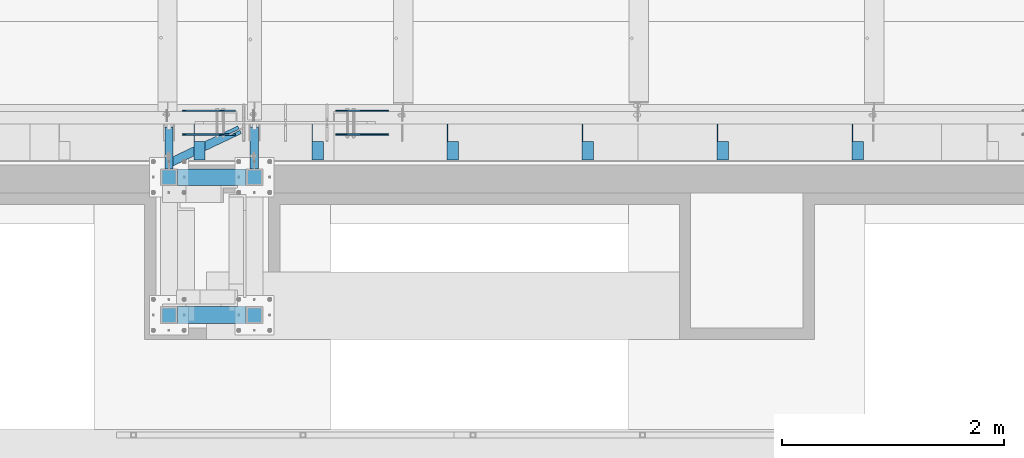
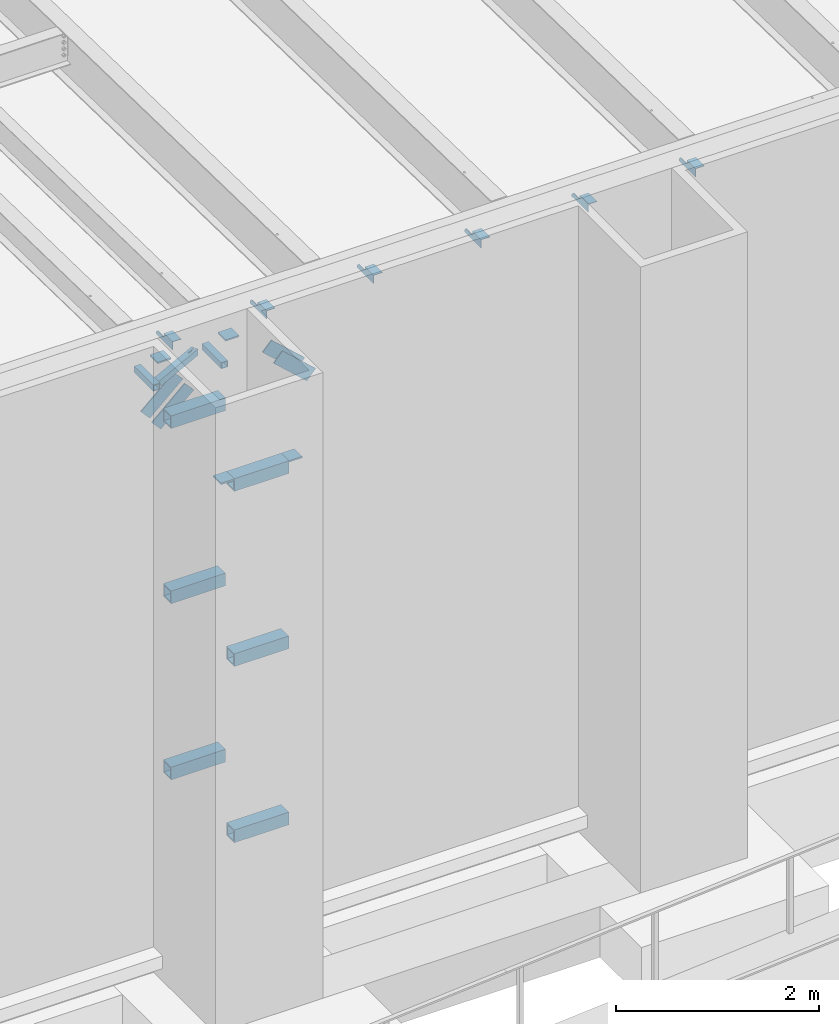
# One storey, part 1178 of 1763: 19 beams, 4 members, 7 elements without a shape of their own.
"""IFC2X3 building model written with IfcOpenShell, lengths in millimetres."""

from ifc_helpers import new_model, si_unit, frame, origin_with_axes, place, context, subcontext, project, spatial, faceted_brep, material, type_object, element, aggregate, save


model = new_model("IFC2X3")

# Units and contexts
model_context = context("Model", 3, precision=1e-05, world=origin_with_axes())
body_context = subcontext(model_context, "Body", "Model", "MODEL_VIEW")
ifc_project = project(units=[si_unit("LENGTHUNIT", "METRE", prefix="MILLI"), si_unit("AREAUNIT", "SQUARE_METRE"), si_unit("VOLUMEUNIT", "CUBIC_METRE"), si_unit("MASSUNIT", "GRAM", prefix="KILO"), si_unit("TIMEUNIT", "SECOND"), si_unit("PLANEANGLEUNIT", "RADIAN"), si_unit("SOLIDANGLEUNIT", "STERADIAN"), si_unit("THERMODYNAMICTEMPERATUREUNIT", "DEGREE_CELSIUS"), si_unit("LUMINOUSINTENSITYUNIT", "LUMEN")], contexts=[model_context])

# Site, building, storey
site_placement = place(None, origin_with_axes())
site = spatial("IfcSite", under=ifc_project, at=site_placement, CompositionType="ELEMENT")
building_placement = place(site_placement, origin_with_axes())
building = spatial("IfcBuilding", under=site, at=building_placement, Name="Undefined", CompositionType="ELEMENT")
storey_placement = place(building_placement, origin_with_axes())
storey = spatial("IfcBuildingStorey", under=building, at=storey_placement, Name="Undefined", CompositionType="ELEMENT", Elevation=0.0)

# Assembly, beams
assembly_1_placement = place(storey_placement, origin_with_axes())
assembly_1 = element("IfcElementAssembly", 1, at=assembly_1_placement, inside=storey, Name="BEAM", AssemblyPlace="NOTDEFINED", PredefinedType="RIGID_FRAME")
ifc_material_1 = material(Name="STEEL/A36")
beam_type_1 = type_object("IfcBeamType", Name="L4X4X1/4", PredefinedType="NOTDEFINED")
beam_1_placement = place(assembly_1_placement, frame((-74765.2055562792, -13727.9060747204, 12153.8999999998), z_axis=(0.0, 0.0, -1.0), x_axis=(0.0, -1.0, 0.0)))
beam_1 = element("IfcBeam", 2, at=beam_1_placement, type_object=beam_type_1, material=ifc_material_1, Name="BRACE", ObjectType="L4X4X1/4", context=body_context, shape_type="Brep", body=[
    faceted_brep([(156.368743896541, 44.4499999999971, -6.34999904595679), (156.368743896541, 50.8000000000029, -6.34999904595679), (156.368743896533, 50.8000000000029, -50.7999999999993), (156.368743896533, -50.8000000000029, -50.7999999999993), (156.368743896535, -50.8000000000029, -44.4500000000007), (156.368743896535, 44.4499999999971, -44.4500000000007), (31.7499984742426, 44.4500000000007, -6.35000000027321), (31.7499984742426, 50.7999999999993, -6.35000038323415), (-1.81898940354586e-10, 44.4500000000371, 50.7999999999374), (-1.96450855582952e-10, 50.8000000000393, 50.7999999999374), (0.0, 50.7999999999993, 25.3999999997268), (0.0, 44.4500000000007, 25.3999999997268), (324.643737794, 44.4500000000007, 50.7999999999993), (324.643737794, 50.7999999999993, 50.7999999999993), (324.643737794, 44.4500000000007, -44.4500000000007), (324.643737794, -50.7999999999993, -44.4500000000007), (324.643737794, -50.7999999999993, -50.7999999999993), (324.643737794, 50.7999999999993, -50.7999999999993)], [[[0, 1, 2, 3, 4, 5]], [[6, 7, 1, 0]], [[8, 9, 10, 11]], [[9, 8, 12, 13]], [[12, 14, 15, 16, 17, 13]], [[15, 14, 5, 4]], [[16, 15, 4, 3]], [[17, 16, 3, 2]], [[10, 9, 13, 17, 2, 1, 7]], [[6, 11, 10, 7]], [[14, 12, 8, 11, 6, 0, 5]]]),
])
beam_2_placement = place(assembly_1_placement, frame((-75984.4055562792, -13727.9060747204, 12153.8999999998), z_axis=(0.0, 0.0, -1.0), x_axis=(0.0, -1.0, 0.0)))
beam_2 = element("IfcBeam", 3, at=beam_2_placement, type_object=beam_type_1, material=ifc_material_1, Name="BRACE", ObjectType="L4X4X1/4", context=body_context, shape_type="Brep", body=[
    faceted_brep([(156.368743896541, 44.4499999999971, -6.34999904595679), (156.368743896541, 50.8000000000029, -6.34999904595679), (156.368743896533, 50.8000000000029, -50.7999999999993), (156.368743896533, -50.8000000000029, -50.7999999999993), (156.368743896535, -50.8000000000029, -44.4500000000007), (156.368743896535, 44.4499999999971, -44.4500000000007), (31.7499984742426, 44.4500000000007, -6.35000000027321), (31.7499984742426, 50.7999999999993, -6.35000038323415), (-1.81898940354586e-10, 44.4500000000371, 50.7999999999374), (-1.96450855582952e-10, 50.8000000000393, 50.7999999999374), (0.0, 50.7999999999993, 25.3999999997268), (0.0, 44.4500000000007, 25.3999999997268), (324.643737794, 44.4500000000007, 50.7999999999993), (324.643737794, 50.7999999999993, 50.7999999999993), (324.643737794, 44.4500000000007, -44.4500000000007), (324.643737794, -50.7999999999993, -44.4500000000007), (324.643737794, -50.7999999999993, -50.7999999999993), (324.643737794, 50.7999999999993, -50.7999999999993)], [[[0, 1, 2, 3, 4, 5]], [[6, 7, 1, 0]], [[8, 9, 10, 11]], [[9, 8, 12, 13]], [[12, 14, 15, 16, 17, 13]], [[15, 14, 5, 4]], [[16, 15, 4, 3]], [[17, 16, 3, 2]], [[10, 9, 13, 17, 2, 1, 7]], [[6, 11, 10, 7]], [[14, 12, 8, 11, 6, 0, 5]]]),
])
beam_3_placement = place(assembly_1_placement, frame((-77203.6055562792, -13727.9060747203, 12153.8999999998), z_axis=(0.0, 0.0, -1.0), x_axis=(0.0, -1.0, 0.0)))
beam_3 = element("IfcBeam", 4, at=beam_3_placement, type_object=beam_type_1, material=ifc_material_1, Name="BRACE", ObjectType="L4X4X1/4", context=body_context, shape_type="Brep", body=[
    faceted_brep([(156.368743896541, 44.4499999999971, -6.34999904595679), (156.368743896541, 50.8000000000029, -6.34999904595679), (156.368743896533, 50.8000000000029, -50.7999999999993), (156.368743896533, -50.8000000000029, -50.7999999999993), (156.368743896535, -50.8000000000029, -44.4500000000007), (156.368743896535, 44.4499999999971, -44.4500000000007), (31.7499984742426, 44.4500000000007, -6.35000000027321), (31.7499984742426, 50.7999999999993, -6.35000038323415), (-1.81898940354586e-10, 44.4500000000371, 50.7999999999374), (-1.96450855582952e-10, 50.8000000000393, 50.7999999999374), (0.0, 50.7999999999993, 25.3999999997268), (0.0, 44.4500000000007, 25.3999999997268), (324.643737794, 44.4500000000007, 50.7999999999993), (324.643737794, 50.7999999999993, 50.7999999999993), (324.643737794, 44.4500000000007, -44.4500000000007), (324.643737794, -50.7999999999993, -44.4500000000007), (324.643737794, -50.7999999999993, -50.7999999999993), (324.643737794, 50.7999999999993, -50.7999999999993)], [[[0, 1, 2, 3, 4, 5]], [[6, 7, 1, 0]], [[8, 9, 10, 11]], [[9, 8, 12, 13]], [[12, 14, 15, 16, 17, 13]], [[15, 14, 5, 4]], [[16, 15, 4, 3]], [[17, 16, 3, 2]], [[10, 9, 13, 17, 2, 1, 7]], [[6, 11, 10, 7]], [[14, 12, 8, 11, 6, 0, 5]]]),
])
beam_4_placement = place(assembly_1_placement, frame((-78422.8055562793, -13727.9060747202, 12153.8999999998), z_axis=(0.0, 0.0, -1.0), x_axis=(0.0, -1.0, 0.0)))
beam_4 = element("IfcBeam", 5, at=beam_4_placement, type_object=beam_type_1, material=ifc_material_1, Name="BRACE", ObjectType="L4X4X1/4", context=body_context, shape_type="Brep", body=[
    faceted_brep([(156.368743896541, 44.4499999999971, -6.34999904595679), (156.368743896541, 50.8000000000029, -6.34999904595679), (156.368743896533, 50.8000000000029, -50.7999999999993), (156.368743896533, -50.8000000000029, -50.7999999999993), (156.368743896535, -50.8000000000029, -44.4500000000007), (156.368743896535, 44.4499999999971, -44.4500000000007), (31.7499984742426, 44.4500000000007, -6.35000000027321), (31.7499984742426, 50.7999999999993, -6.35000038323415), (-1.81898940354586e-10, 44.4500000000371, 50.7999999999374), (-1.96450855582952e-10, 50.8000000000393, 50.7999999999374), (0.0, 50.7999999999993, 25.3999999997268), (0.0, 44.4500000000007, 25.3999999997268), (324.643737794, 44.4500000000007, 50.7999999999993), (324.643737794, 50.7999999999993, 50.7999999999993), (324.643737794, 44.4500000000007, -44.4500000000007), (324.643737794, -50.7999999999993, -44.4500000000007), (324.643737794, -50.7999999999993, -50.7999999999993), (324.643737794, 50.7999999999993, -50.7999999999993)], [[[0, 1, 2, 3, 4, 5]], [[6, 7, 1, 0]], [[8, 9, 10, 11]], [[9, 8, 12, 13]], [[12, 14, 15, 16, 17, 13]], [[15, 14, 5, 4]], [[16, 15, 4, 3]], [[17, 16, 3, 2]], [[10, 9, 13, 17, 2, 1, 7]], [[6, 11, 10, 7]], [[14, 12, 8, 11, 6, 0, 5]]]),
])
beam_5_placement = place(assembly_1_placement, frame((-79642.0055562793, -13727.9060747201, 12153.8999999998), z_axis=(0.0, 0.0, -1.0), x_axis=(0.0, -1.0, 0.0)))
beam_5 = element("IfcBeam", 6, at=beam_5_placement, type_object=beam_type_1, material=ifc_material_1, Name="BRACE", ObjectType="L4X4X1/4", context=body_context, shape_type="Brep", body=[
    faceted_brep([(156.368743896541, 44.4499999999971, -6.34999904595679), (156.368743896541, 50.8000000000029, -6.34999904595679), (156.368743896533, 50.8000000000029, -50.7999999999993), (156.368743896533, -50.8000000000029, -50.7999999999993), (156.368743896535, -50.8000000000029, -44.4500000000007), (156.368743896535, 44.4499999999971, -44.4500000000007), (31.7499984742426, 44.4500000000007, -6.35000000027321), (31.7499984742426, 50.7999999999993, -6.35000038323415), (-1.81898940354586e-10, 44.4500000000371, 50.7999999999374), (-1.96450855582952e-10, 50.8000000000393, 50.7999999999374), (0.0, 50.7999999999993, 25.3999999997268), (0.0, 44.4500000000007, 25.3999999997268), (324.643737794, 44.4500000000007, 50.7999999999993), (324.643737794, 50.7999999999993, 50.7999999999993), (324.643737794, 44.4500000000007, -44.4500000000007), (324.643737794, -50.7999999999993, -44.4500000000007), (324.643737794, -50.7999999999993, -50.7999999999993), (324.643737794, 50.7999999999993, -50.7999999999993)], [[[0, 1, 2, 3, 4, 5]], [[6, 7, 1, 0]], [[8, 9, 10, 11]], [[9, 8, 12, 13]], [[12, 14, 15, 16, 17, 13]], [[15, 14, 5, 4]], [[16, 15, 4, 3]], [[17, 16, 3, 2]], [[10, 9, 13, 17, 2, 1, 7]], [[6, 11, 10, 7]], [[14, 12, 8, 11, 6, 0, 5]]]),
])
beam_6_placement = place(assembly_1_placement, frame((-80708.8055562793, -13727.9060747201, 12153.8999999998), z_axis=(0.0, 0.0, -1.0), x_axis=(0.0, -1.0, 0.0)))
beam_6 = element("IfcBeam", 7, at=beam_6_placement, type_object=beam_type_1, material=ifc_material_1, Name="BRACE", ObjectType="L4X4X1/4", context=body_context, shape_type="Brep", body=[
    faceted_brep([(156.368743896541, 44.4499999999971, -6.34999904595679), (156.368743896541, 50.8000000000029, -6.34999904595679), (156.368743896533, 50.8000000000029, -50.7999999999993), (156.368743896533, -50.8000000000029, -50.7999999999993), (156.368743896535, -50.8000000000029, -44.4500000000007), (156.368743896535, 44.4499999999971, -44.4500000000007), (31.7499984742426, 44.4500000000007, -6.35000000027321), (31.7499984742426, 50.7999999999993, -6.35000038323415), (-1.81898940354586e-10, 44.4500000000371, 50.7999999999374), (-1.96450855582952e-10, 50.8000000000393, 50.7999999999374), (0.0, 50.7999999999993, 25.3999999997268), (0.0, 44.4500000000007, 25.3999999997268), (324.643737794, 44.4500000000007, 50.7999999999993), (324.643737794, 50.7999999999993, 50.7999999999993), (324.643737794, 44.4500000000007, -44.4500000000007), (324.643737794, -50.7999999999993, -44.4500000000007), (324.643737794, -50.7999999999993, -50.7999999999993), (324.643737794, 50.7999999999993, -50.7999999999993)], [[[0, 1, 2, 3, 4, 5]], [[6, 7, 1, 0]], [[8, 9, 10, 11]], [[9, 8, 12, 13]], [[12, 14, 15, 16, 17, 13]], [[15, 14, 5, 4]], [[16, 15, 4, 3]], [[17, 16, 3, 2]], [[10, 9, 13, 17, 2, 1, 7]], [[6, 11, 10, 7]], [[14, 12, 8, 11, 6, 0, 5]]]),
])
aggregate(assembly_1, [beam_1, beam_2, beam_3, beam_4, beam_5, beam_6])

# Assembly, beam
assembly_2_placement = place(storey_placement, origin_with_axes())
assembly_2 = element("IfcElementAssembly", 8, at=assembly_2_placement, inside=storey, Name="BEAM", AssemblyPlace="NOTDEFINED", PredefinedType="RIGID_FRAME")
ifc_material_2 = material()
beam_type_2 = type_object("IfcBeamType", Name="HSS3X3X1/4", PredefinedType="NOTDEFINED")
beam_7_placement = place(assembly_2_placement, frame((-80984.1623728712, -14081.1242675181, 11785.6), z_axis=(0.0, 0.0, 1.0), x_axis=(0.903891808817175, 0.427761145913482, 0.0)))
beam_7 = element("IfcBeam", 9, at=beam_7_placement, type_object=beam_type_2, material=ifc_material_2, Name="BEAM", ObjectType="HSS3X3X1/4", context=body_context, shape_type="Brep", body=[
    faceted_brep([(705.172441220871, 6.3451713315626, 38.1000000000004), (597.221478940919, 6.32881239638664, 38.1000000000004), (597.221478940919, 6.32881239638664, 31.75), (705.172441220871, 6.3451713315626, 31.75), (597.223403504337, -6.3711874577275, 38.1000000000004), (597.223403504337, -6.3711874577275, 31.75), (705.172441220871, -6.35482881420467, 38.1000000000004), (705.172441220871, -6.35482881420467, 31.75), (705.172441220871, 6.3451713315626, -31.75), (597.221478940904, 6.32881239639391, -31.75), (597.221478940904, 6.32881239639391, -38.1000000000004), (705.172441220871, 6.3451713315626, -38.1000000000004), (597.223403504322, -6.3711874577275, -31.75), (597.223403504322, -6.3711874577275, -38.1000000000004), (705.172441220871, -6.35482881420467, -31.75), (705.172441220871, -6.35482881420467, -38.1000000000004), (57.1765513156497, 31.7500000000274, 31.75), (57.1765513156497, 31.7500000000274, -31.75), (705.172441220901, 31.749999999025, -31.75), (705.172441220901, 31.749999999025, 31.75), (705.172441220857, -31.7500000009095, 31.75), (27.1255734098886, -31.7499999999308, 31.75), (27.1255734098886, -31.7499999999308, -31.75), (705.172441220857, -31.7500000009095, -31.75), (24.1204756193183, -38.0999999999257, -38.1000000000004), (24.1204756193183, -38.0999999999257, 38.1000000000004), (60.18164910622, 38.1000000000241, 38.1000000000004), (60.18164910622, 38.1000000000241, -38.1000000000004), (705.172441220915, 38.0999999990163, 38.1000000000004), (705.172441220915, 38.0999999990163, -38.1000000000004), (705.172441220842, -38.1000000009008, -38.1000000000004), (705.172441220842, -38.1000000009008, 38.1000000000004)], [[[0, 1, 2, 3]], [[4, 5, 2, 1]], [[6, 7, 5, 4]], [[8, 9, 10, 11]], [[12, 13, 10, 9]], [[14, 15, 13, 12]], [[16, 17, 18, 19]], [[20, 21, 16, 19, 3, 2, 5, 7]], [[22, 21, 20, 23]], [[9, 8, 18, 17, 22, 23, 14, 12]], [[24, 25, 26, 27], [16, 21, 22, 17]], [[27, 26, 28, 29]], [[19, 18, 8, 11, 29, 28, 0, 3]], [[30, 24, 27, 29, 11, 10, 13, 15]], [[25, 24, 30, 31]], [[1, 0, 28, 26, 25, 31, 6, 4]], [[31, 30, 15, 14, 23, 20, 7, 6]]]),
])
aggregate(assembly_2, [beam_7])

assembly_3_placement = place(storey_placement, origin_with_axes())
assembly_3 = element("IfcElementAssembly", 10, at=assembly_3_placement, inside=storey, Name="BEAM", AssemblyPlace="NOTDEFINED", PredefinedType="RIGID_FRAME")
beam_8_placement = place(assembly_3_placement, frame((-80212.6373728729, -14208.1242675197, 11785.6), z_axis=(0.0, 0.0, 1.0), x_axis=(0.0, 1.0, 0.0)))
beam_8 = element("IfcBeam", 11, at=beam_8_placement, type_object=beam_type_2, material=ifc_material_2, Name="BEAM", ObjectType="HSS3X3X1/4", context=body_context, shape_type="Brep", body=[
    faceted_brep([(76.2000000000007, 31.75, -31.75), (76.2000000000007, -31.75, -31.75), (454.818198901074, -31.75, -31.75), (454.818198901074, 31.75, -31.75), (76.2000000000007, -31.75, 31.75), (454.818198901074, -31.75, 31.75), (76.2000000000007, 31.75, 31.75), (454.818198901074, 31.75, 31.75), (76.2000000000007, 38.1000000000058, -38.1000000000004), (76.2000000000007, 38.1000000000058, 38.1000000000004), (454.818198901074, 38.1000000000058, 38.1000000000004), (454.818198901074, 38.1000000000058, -38.1000000000004), (76.2000000000007, -38.1000000000058, 38.1000000000004), (454.818198901074, -38.1000000000058, 38.1000000000004), (76.2000000000007, -38.1000000000058, -38.1000000000004), (454.818198901074, -38.1000000000058, -38.1000000000004)], [[[0, 1, 2, 3]], [[1, 4, 5, 2]], [[4, 6, 7, 5]], [[6, 0, 3, 7]], [[8, 9, 10, 11]], [[9, 12, 13, 10]], [[12, 14, 15, 13]], [[14, 8, 11, 15]], [[13, 15, 11, 10], [5, 7, 3, 2]], [[14, 12, 9, 8], [6, 4, 1, 0]]]),
])
aggregate(assembly_3, [beam_8])

assembly_4_placement = place(storey_placement, origin_with_axes())
assembly_4 = element("IfcElementAssembly", 12, at=assembly_4_placement, inside=storey, Name="BEAM", AssemblyPlace="NOTDEFINED", PredefinedType="RIGID_FRAME")
beam_9_placement = place(assembly_4_placement, frame((-80984.1623728712, -14208.1242675181, 11785.6), z_axis=(0.0, 0.0, 1.0), x_axis=(0.0, 1.0, 0.0)))
beam_9 = element("IfcBeam", 13, at=beam_9_placement, type_object=beam_type_2, material=ifc_material_2, Name="BEAM", ObjectType="HSS3X3X1/4", context=body_context, shape_type="Brep", body=[
    faceted_brep([(76.2000000000007, 31.75, -31.75), (76.2000000000007, -31.75, -31.75), (454.818198901074, -31.75, -31.75), (454.818198901074, 31.75, -31.75), (76.2000000000007, -31.75, 31.75), (454.818198901074, -31.75, 31.75), (76.2000000000007, 31.75, 31.75), (454.818198901074, 31.75, 31.75), (76.2000000000007, 38.1000000000058, -38.1000000000004), (76.2000000000007, 38.1000000000058, 38.1000000000004), (454.818198901074, 38.1000000000058, 38.1000000000004), (454.818198901074, 38.1000000000058, -38.1000000000004), (76.2000000000007, -38.1000000000058, 38.1000000000004), (454.818198901074, -38.1000000000058, 38.1000000000004), (76.2000000000007, -38.1000000000058, -38.1000000000004), (454.818198901074, -38.1000000000058, -38.1000000000004)], [[[0, 1, 2, 3]], [[1, 4, 5, 2]], [[4, 6, 7, 5]], [[6, 0, 3, 7]], [[8, 9, 10, 11]], [[9, 12, 13, 10]], [[12, 14, 15, 13]], [[14, 8, 11, 15]], [[13, 15, 11, 10], [5, 7, 3, 2]], [[14, 12, 9, 8], [6, 4, 1, 0]]]),
])
aggregate(assembly_4, [beam_9])

# Assembly, beams
assembly_5_placement = place(storey_placement, origin_with_axes())
assembly_5 = element("IfcElementAssembly", 14, at=assembly_5_placement, inside=storey, Name="FRAME", AssemblyPlace="NOTDEFINED", PredefinedType="RIGID_FRAME")
beam_type_3 = type_object("IfcBeamType", PredefinedType="NOTDEFINED")
beam_10_placement = place(assembly_5_placement, frame((-80212.6370783858, -14284.3242675181, 12195.175), z_axis=(1.0, 0.0, 0.0), x_axis=(0.0, 1.0, 0.0)))
beam_10 = element("IfcBeam", 15, at=beam_10_placement, type_object=beam_type_3, material=ifc_material_1, Name="PLATE", context=body_context, shape_type="Brep", body=[
    faceted_brep([(0.0, 9.52499999999964, -76.1999999999971), (0.0, 9.52499999999964, 76.1999999999971), (152.400000000001, 9.52499999999964, 76.1999999999971), (152.400000000001, 9.52499999999964, -76.1999999999971), (0.0, -9.52499999999964, 76.1999999999971), (152.400000000001, -9.52499999999964, 76.1999999999971), (0.0, -9.52499999999964, -76.1999999999971), (152.400000000001, -9.52499999999964, -76.1999999999971)], [[[0, 1, 2, 3]], [[1, 4, 5, 2]], [[4, 6, 7, 5]], [[6, 0, 3, 7]], [[5, 7, 3, 2]], [[6, 4, 1, 0]]]),
])
beam_11_placement = place(assembly_5_placement, frame((-80984.1622736984, -14284.3242675181, 12195.175), z_axis=(1.0, 0.0, 0.0), x_axis=(0.0, 1.0, 0.0)))
beam_11 = element("IfcBeam", 16, at=beam_11_placement, type_object=beam_type_3, material=ifc_material_1, Name="PLATE", context=body_context, shape_type="Brep", body=[
    faceted_brep([(0.0, 9.52499999999964, -76.1999999999971), (0.0, 9.52499999999964, 76.1999999999971), (152.400000000001, 9.52499999999964, 76.1999999999971), (152.400000000001, 9.52499999999964, -76.1999999999971), (0.0, -9.52499999999964, 76.1999999999971), (152.400000000001, -9.52499999999964, 76.1999999999971), (0.0, -9.52499999999964, -76.1999999999971), (152.400000000001, -9.52499999999964, -76.1999999999971)], [[[0, 1, 2, 3]], [[1, 4, 5, 2]], [[4, 6, 7, 5]], [[6, 0, 3, 7]], [[5, 7, 3, 2]], [[6, 4, 1, 0]]]),
])
beam_12_placement = place(assembly_5_placement, frame((-80212.6370783858, -15528.9242675181, 11496.675), z_axis=(1.0, 0.0, 0.0), x_axis=(0.0, 1.0, 0.0)))
beam_12 = element("IfcBeam", 17, at=beam_12_placement, type_object=beam_type_3, material=ifc_material_1, Name="PLATE", context=body_context, shape_type="Brep", body=[
    faceted_brep([(0.0, 9.52499999999964, -76.1999999999971), (0.0, 9.52499999999964, 76.1999999999971), (152.400000000001, 9.52499999999964, 76.1999999999971), (152.400000000001, 9.52499999999964, -76.1999999999971), (0.0, -9.52499999999964, 76.1999999999971), (152.400000000001, -9.52499999999964, 76.1999999999971), (0.0, -9.52499999999964, -76.1999999999971), (152.400000000001, -9.52499999999964, -76.1999999999971)], [[[0, 1, 2, 3]], [[1, 4, 5, 2]], [[4, 6, 7, 5]], [[6, 0, 3, 7]], [[5, 7, 3, 2]], [[6, 4, 1, 0]]]),
])
beam_13_placement = place(assembly_5_placement, frame((-80984.1622736984, -15528.9242675181, 11496.675), z_axis=(1.0, 0.0, 0.0), x_axis=(0.0, 1.0, 0.0)))
beam_13 = element("IfcBeam", 18, at=beam_13_placement, type_object=beam_type_3, material=ifc_material_1, Name="PLATE", context=body_context, shape_type="Brep", body=[
    faceted_brep([(0.0, 9.52499999999964, -76.1999999999971), (0.0, 9.52499999999964, 76.1999999999971), (152.400000000001, 9.52499999999964, 76.1999999999971), (152.400000000001, 9.52499999999964, -76.1999999999971), (0.0, -9.52499999999964, 76.1999999999971), (152.400000000001, -9.52499999999964, 76.1999999999971), (0.0, -9.52499999999964, -76.1999999999971), (152.400000000001, -9.52499999999964, -76.1999999999971)], [[[0, 1, 2, 3]], [[1, 4, 5, 2]], [[4, 6, 7, 5]], [[6, 0, 3, 7]], [[5, 7, 3, 2]], [[6, 4, 1, 0]]]),
])
beam_type_4 = type_object("IfcBeamType", Name="HSS6X6X5/8", PredefinedType="NOTDEFINED")
beam_14_placement = place(assembly_5_placement, frame((-80984.1622248702, -14208.1242675181, 11430.0), z_axis=(0.0, 0.0, 1.0), x_axis=(1.0, 0.0, 0.0)))
beam_14 = element("IfcBeam", 19, at=beam_14_placement, type_object=beam_type_4, material=ifc_material_2, Name="BEAM", ObjectType="HSS6X6X5/8", context=body_context, shape_type="Brep", body=[
    faceted_brep([(76.1999511718459, 60.3250000000007, -60.3250000000007), (76.1999511718459, -60.3250000000007, -60.3250000000007), (695.325146484363, -60.3250000000007, -60.3250000000007), (695.325146484363, 60.3250000000007, -60.3250000000007), (76.1999511718459, -60.3250000000007, 60.3250000000007), (695.325146484363, -60.3250000000007, 60.3250000000007), (76.1999511718459, 60.3250000000007, 60.3250000000007), (695.325146484363, 60.3250000000007, 60.3250000000007), (76.1999511718459, 76.2000000000007, -76.2000000000007), (76.1999511718459, 76.2000000000007, 76.2000000000007), (695.325146484363, 76.2000000000007, 76.2000000000007), (695.325146484363, 76.2000000000007, -76.2000000000007), (76.1999511718459, -76.2000000000007, 76.2000000000007), (695.325146484363, -76.2000000000007, 76.2000000000007), (76.1999511718459, -76.2000000000007, -76.2000000000007), (695.325146484363, -76.2000000000007, -76.2000000000007)], [[[0, 1, 2, 3]], [[1, 4, 5, 2]], [[4, 6, 7, 5]], [[6, 0, 3, 7]], [[8, 9, 10, 11]], [[9, 12, 13, 10]], [[12, 14, 15, 13]], [[14, 8, 11, 15]], [[13, 15, 11, 10], [5, 7, 3, 2]], [[14, 12, 9, 8], [6, 4, 1, 0]]]),
])
beam_15_placement = place(assembly_5_placement, frame((-80984.1622248702, -15452.7242675181, 11430.0), z_axis=(0.0, 0.0, 1.0), x_axis=(1.0, 0.0, 0.0)))
beam_15 = element("IfcBeam", 20, at=beam_15_placement, type_object=beam_type_4, material=ifc_material_2, Name="BEAM", ObjectType="HSS6X6X5/8", context=body_context, shape_type="Brep", body=[
    faceted_brep([(76.1999511718459, 60.3250000000007, -60.3250000000007), (76.1999511718459, -60.3250000000007, -60.3250000000007), (695.325146484363, -60.3250000000007, -60.3250000000007), (695.325146484363, 60.3250000000007, -60.3250000000007), (76.1999511718459, -60.3250000000007, 60.3250000000007), (695.325146484363, -60.3250000000007, 60.3250000000007), (76.1999511718459, 60.3250000000007, 60.3250000000007), (695.325146484363, 60.3250000000007, 60.3250000000007), (76.1999511718459, 76.2000000000007, -76.2000000000007), (76.1999511718459, 76.2000000000007, 76.2000000000007), (695.325146484363, 76.2000000000007, 76.2000000000007), (695.325146484363, 76.2000000000007, -76.2000000000007), (76.1999511718459, -76.2000000000007, 76.2000000000007), (695.325146484363, -76.2000000000007, 76.2000000000007), (76.1999511718459, -76.2000000000007, -76.2000000000007), (695.325146484363, -76.2000000000007, -76.2000000000007)], [[[0, 1, 2, 3]], [[1, 4, 5, 2]], [[4, 6, 7, 5]], [[6, 0, 3, 7]], [[8, 9, 10, 11]], [[9, 12, 13, 10]], [[12, 14, 15, 13]], [[14, 8, 11, 15]], [[13, 15, 11, 10], [5, 7, 3, 2]], [[14, 12, 9, 8], [6, 4, 1, 0]]]),
])
beam_16_placement = place(assembly_5_placement, frame((-80984.1622248702, -14208.1242675181, 9325.96736125847), z_axis=(0.0, 0.0, 1.0), x_axis=(1.0, 0.0, 0.0)))
beam_16 = element("IfcBeam", 21, at=beam_16_placement, type_object=beam_type_4, material=ifc_material_2, Name="BEAM", ObjectType="HSS6X6X5/8", context=body_context, shape_type="Brep", body=[
    faceted_brep([(76.1999511718459, 60.3250000000007, -60.3250000000007), (76.1999511718459, -60.3250000000007, -60.3250000000007), (695.325146484363, -60.3250000000007, -60.3250000000007), (695.325146484363, 60.3250000000007, -60.3250000000007), (76.1999511718459, -60.3250000000007, 60.3250000000007), (695.325146484363, -60.3250000000007, 60.3250000000007), (76.1999511718459, 60.3250000000007, 60.3250000000007), (695.325146484363, 60.3250000000007, 60.3250000000007), (76.1999511718459, 76.2000000000007, -76.2000000000007), (76.1999511718459, 76.2000000000007, 76.2000000000007), (695.325146484363, 76.2000000000007, 76.2000000000007), (695.325146484363, 76.2000000000007, -76.2000000000007), (76.1999511718459, -76.2000000000007, 76.2000000000007), (695.325146484363, -76.2000000000007, 76.2000000000007), (76.1999511718459, -76.2000000000007, -76.2000000000007), (695.325146484363, -76.2000000000007, -76.2000000000007)], [[[0, 1, 2, 3]], [[1, 4, 5, 2]], [[4, 6, 7, 5]], [[6, 0, 3, 7]], [[8, 9, 10, 11]], [[9, 12, 13, 10]], [[12, 14, 15, 13]], [[14, 8, 11, 15]], [[13, 15, 11, 10], [5, 7, 3, 2]], [[14, 12, 9, 8], [6, 4, 1, 0]]]),
])
beam_17_placement = place(assembly_5_placement, frame((-80984.1622248702, -15452.7242675181, 9325.9676945918), z_axis=(0.0, 0.0, 1.0), x_axis=(1.0, 0.0, 0.0)))
beam_17 = element("IfcBeam", 22, at=beam_17_placement, type_object=beam_type_4, material=ifc_material_2, Name="BEAM", ObjectType="HSS6X6X5/8", context=body_context, shape_type="Brep", body=[
    faceted_brep([(76.1999511718459, 60.3250000000007, -60.3250000000007), (76.1999511718459, -60.3250000000007, -60.3250000000007), (695.325146484363, -60.3250000000007, -60.3250000000007), (695.325146484363, 60.3250000000007, -60.3250000000007), (76.1999511718459, -60.3250000000007, 60.3250000000007), (695.325146484363, -60.3250000000007, 60.3250000000007), (76.1999511718459, 60.3250000000007, 60.3250000000007), (695.325146484363, 60.3250000000007, 60.3250000000007), (76.1999511718459, 76.2000000000007, -76.2000000000007), (76.1999511718459, 76.2000000000007, 76.2000000000007), (695.325146484363, 76.2000000000007, 76.2000000000007), (695.325146484363, 76.2000000000007, -76.2000000000007), (76.1999511718459, -76.2000000000007, 76.2000000000007), (695.325146484363, -76.2000000000007, 76.2000000000007), (76.1999511718459, -76.2000000000007, -76.2000000000007), (695.325146484363, -76.2000000000007, -76.2000000000007)], [[[0, 1, 2, 3]], [[1, 4, 5, 2]], [[4, 6, 7, 5]], [[6, 0, 3, 7]], [[8, 9, 10, 11]], [[9, 12, 13, 10]], [[12, 14, 15, 13]], [[14, 8, 11, 15]], [[13, 15, 11, 10], [5, 7, 3, 2]], [[14, 12, 9, 8], [6, 4, 1, 0]]]),
])
beam_18_placement = place(assembly_5_placement, frame((-80984.162127214, -14208.1242675181, 7209.43305003711), z_axis=(0.0, 0.0, 1.0), x_axis=(1.0, 0.0, 0.0)))
beam_18 = element("IfcBeam", 23, at=beam_18_placement, type_object=beam_type_4, material=ifc_material_2, Name="BEAM", ObjectType="HSS6X6X5/8", context=body_context, shape_type="Brep", body=[
    faceted_brep([(76.1998535156017, 60.3250000000007, -60.3249999999998), (76.1998535156017, -60.3250000000007, -60.3249999999998), (695.325048828119, -60.3250000000007, -60.3249999999998), (695.325048828119, 60.3250000000007, -60.3249999999998), (76.1998535156017, -60.3250000000007, 60.3249999999998), (695.325048828119, -60.3250000000007, 60.3249999999998), (76.1998535156017, 60.3250000000007, 60.3249999999998), (695.325048828119, 60.3250000000007, 60.3249999999998), (76.1998535156017, 76.2000000000007, -76.1999999999998), (76.1998535156017, 76.2000000000007, 76.1999999999998), (695.325048828119, 76.2000000000007, 76.1999999999998), (695.325048828119, 76.2000000000007, -76.1999999999998), (76.1998535156017, -76.2000000000007, 76.1999999999998), (695.325048828119, -76.2000000000007, 76.1999999999998), (76.1998535156017, -76.2000000000007, -76.1999999999998), (695.325048828119, -76.2000000000007, -76.1999999999998)], [[[0, 1, 2, 3]], [[1, 4, 5, 2]], [[4, 6, 7, 5]], [[6, 0, 3, 7]], [[8, 9, 10, 11]], [[9, 12, 13, 10]], [[12, 14, 15, 13]], [[14, 8, 11, 15]], [[13, 15, 11, 10], [5, 7, 3, 2]], [[14, 12, 9, 8], [6, 4, 1, 0]]]),
])
beam_19_placement = place(assembly_5_placement, frame((-80984.162127214, -15452.7242675181, 7209.43271670378), z_axis=(0.0, 0.0, 1.0), x_axis=(1.0, 0.0, 0.0)))
beam_19 = element("IfcBeam", 24, at=beam_19_placement, type_object=beam_type_4, material=ifc_material_2, Name="BEAM", ObjectType="HSS6X6X5/8", context=body_context, shape_type="Brep", body=[
    faceted_brep([(76.1998535156017, 60.3250000000007, -60.3249999999998), (76.1998535156017, -60.3250000000007, -60.3249999999998), (695.325048828119, -60.3250000000007, -60.3249999999998), (695.325048828119, 60.3250000000007, -60.3249999999998), (76.1998535156017, -60.3250000000007, 60.3249999999998), (695.325048828119, -60.3250000000007, 60.3249999999998), (76.1998535156017, 60.3250000000007, 60.3249999999998), (695.325048828119, 60.3250000000007, 60.3249999999998), (76.1998535156017, 76.2000000000007, -76.1999999999998), (76.1998535156017, 76.2000000000007, 76.1999999999998), (695.325048828119, 76.2000000000007, 76.1999999999998), (695.325048828119, 76.2000000000007, -76.1999999999998), (76.1998535156017, -76.2000000000007, 76.1999999999998), (695.325048828119, -76.2000000000007, 76.1999999999998), (76.1998535156017, -76.2000000000007, -76.1999999999998), (695.325048828119, -76.2000000000007, -76.1999999999998)], [[[0, 1, 2, 3]], [[1, 4, 5, 2]], [[4, 6, 7, 5]], [[6, 0, 3, 7]], [[8, 9, 10, 11]], [[9, 12, 13, 10]], [[12, 14, 15, 13]], [[14, 8, 11, 15]], [[13, 15, 11, 10], [5, 7, 3, 2]], [[14, 12, 9, 8], [6, 4, 1, 0]]]),
])
aggregate(assembly_5, [beam_10, beam_11, beam_12, beam_13, beam_14, beam_15, beam_16, beam_17, beam_18, beam_19])

# Assembly, members
assembly_6_placement = place(storey_placement, origin_with_axes())
assembly_6 = element("IfcElementAssembly", 25, at=assembly_6_placement, inside=storey, Name="V. BRACE", AssemblyPlace="NOTDEFINED", PredefinedType="RIGID_FRAME")
member_type = type_object("IfcMemberType", PredefinedType="NOTDEFINED")
member_1_placement = place(assembly_6_placement, frame((-80813.2283929028, -13608.05, 11077.1019024724), z_axis=(-0.671476028756224, 0.0, 0.741026276730974), x_axis=(0.741026276730974, 0.0, 0.671476028756224)))
member_1 = element("IfcMember", 26, at=member_1_placement, type_object=member_type, material=ifc_material_1, Name="PLATE", context=body_context, shape_type="Brep", body=[
    faceted_brep([(4.36557456851006e-11, 6.35000000000036, -76.2000000000044), (-4.72937244921923e-11, 6.35000000000036, 76.1999999999898), (507.999999999498, 6.35000000000036, 76.1999999995642), (507.999999999589, 6.35000000000036, -76.20000000043), (-4.72937244921923e-11, -6.35000000000036, 76.1999999999898), (507.999999999498, -6.35000000000036, 76.1999999995642), (4.36557456851006e-11, -6.35000000000036, -76.2000000000044), (507.999999999589, -6.35000000000036, -76.20000000043)], [[[0, 1, 2, 3]], [[1, 4, 5, 2]], [[4, 6, 7, 5]], [[6, 0, 3, 7]], [[5, 7, 3, 2]], [[6, 4, 1, 0]]]),
])
member_2_placement = place(assembly_6_placement, frame((-80813.2283929028, -13823.95, 11077.1019024724), z_axis=(-0.671476028756224, 0.0, 0.741026276730974), x_axis=(0.741026276730974, 0.0, 0.671476028756224)))
member_2 = element("IfcMember", 27, at=member_2_placement, type_object=member_type, material=ifc_material_1, Name="PLATE", context=body_context, shape_type="Brep", body=[
    faceted_brep([(4.36557456851006e-11, 6.35000000000036, -76.2000000000044), (-4.72937244921923e-11, 6.35000000000036, 76.1999999999898), (507.999999999498, 6.35000000000036, 76.1999999995642), (507.999999999589, 6.35000000000036, -76.20000000043), (-4.72937244921923e-11, -6.35000000000036, 76.1999999999898), (507.999999999498, -6.35000000000036, 76.1999999995642), (4.36557456851006e-11, -6.35000000000036, -76.2000000000044), (507.999999999589, -6.35000000000036, -76.20000000043)], [[[0, 1, 2, 3]], [[1, 4, 5, 2]], [[4, 6, 7, 5]], [[6, 0, 3, 7]], [[5, 7, 3, 2]], [[6, 4, 1, 0]]]),
])
aggregate(assembly_6, [member_1, member_2])

assembly_7_placement = place(storey_placement, origin_with_axes())
assembly_7 = element("IfcElementAssembly", 28, at=assembly_7_placement, inside=storey, Name="V. BRACE", AssemblyPlace="NOTDEFINED", PredefinedType="RIGID_FRAME")
member_3_placement = place(assembly_7_placement, frame((-79053.2461578272, -13823.95, 11077.1019054929), z_axis=(0.671476028756224, 0.0, 0.741026276730974), x_axis=(-0.741026276730974, 0.0, 0.671476028756224)))
member_3 = element("IfcMember", 29, at=member_3_placement, type_object=member_type, material=ifc_material_1, Name="PLATE", context=body_context, shape_type="Brep", body=[
    faceted_brep([(4.36557456851006e-11, 6.35000000000036, -76.2000000000044), (-4.72937244921923e-11, 6.35000000000036, 76.1999999999898), (507.999999999498, 6.35000000000036, 76.1999999995642), (507.999999999589, 6.35000000000036, -76.20000000043), (-4.72937244921923e-11, -6.35000000000036, 76.1999999999898), (507.999999999498, -6.35000000000036, 76.1999999995642), (4.36557456851006e-11, -6.35000000000036, -76.2000000000044), (507.999999999589, -6.35000000000036, -76.20000000043)], [[[0, 1, 2, 3]], [[1, 4, 5, 2]], [[4, 6, 7, 5]], [[6, 0, 3, 7]], [[5, 7, 3, 2]], [[6, 4, 1, 0]]]),
])
member_4_placement = place(assembly_7_placement, frame((-79053.2461578272, -13608.05, 11077.1019054929), z_axis=(0.671476028756224, 0.0, 0.741026276730974), x_axis=(-0.741026276730974, 0.0, 0.671476028756224)))
member_4 = element("IfcMember", 30, at=member_4_placement, type_object=member_type, material=ifc_material_1, Name="PLATE", context=body_context, shape_type="Brep", body=[
    faceted_brep([(4.36557456851006e-11, 6.35000000000036, -76.2000000000044), (-4.72937244921923e-11, 6.35000000000036, 76.1999999999898), (507.999999999498, 6.35000000000036, 76.1999999995642), (507.999999999589, 6.35000000000036, -76.20000000043), (-4.72937244921923e-11, -6.35000000000036, 76.1999999999898), (507.999999999498, -6.35000000000036, 76.1999999995642), (4.36557456851006e-11, -6.35000000000036, -76.2000000000044), (507.999999999589, -6.35000000000036, -76.20000000043)], [[[0, 1, 2, 3]], [[1, 4, 5, 2]], [[4, 6, 7, 5]], [[6, 0, 3, 7]], [[5, 7, 3, 2]], [[6, 4, 1, 0]]]),
])
aggregate(assembly_7, [member_3, member_4])

save(model, "model.ifc")
